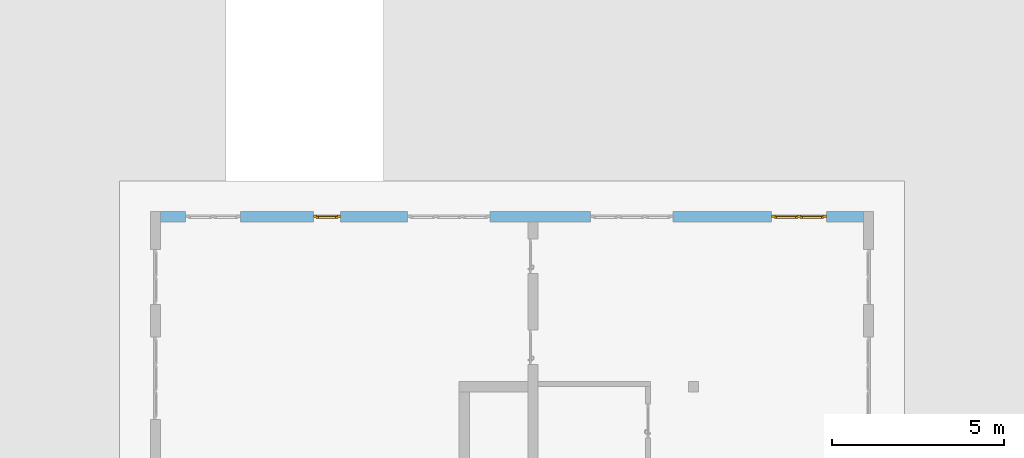
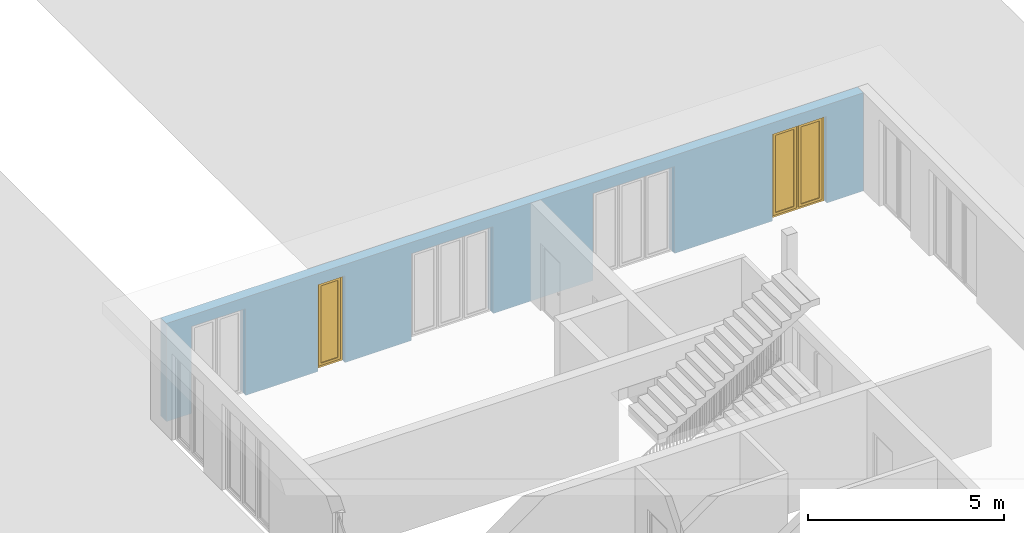
# One storey, part 16 of 23: 2 windows, 5 openings, plus 1 element that does not belong to this part.
"""IFC4 building model written with IfcOpenShell, lengths in metres."""

from ifc_helpers import new_model, entity, si_unit, converted_unit, derived_unit, direction, frame, origin_with_axes, place, context, subcontext, project, spatial, polygons, source, transform, mapped, material, type_object, element, fill, save


model = new_model("IFC4")

# Units and contexts
model_context = context("Model", 3, precision=1e-05, world=origin_with_axes(), true_north=direction((0.0, 1.0)))
body_context = subcontext(model_context, "Body", "Model", "MODEL_VIEW")
ifc_project = project(units=[si_unit("LENGTHUNIT", "METRE"), si_unit("AREAUNIT", "SQUARE_METRE"), si_unit("VOLUMEUNIT", "CUBIC_METRE"), converted_unit("PLANEANGLEUNIT", "DEGREE", entity("IfcPlaneAngleMeasure", 0.0174532925199), si_unit("PLANEANGLEUNIT", "RADIAN"), dimensions=[0, 0, 0, 0, 0, 0, 0]), converted_unit("TIMEUNIT", "Year", entity("IfcTimeMeasure", 31556926.0), si_unit("TIMEUNIT", "SECOND"), dimensions=[0, 0, 1, 0, 0, 0, 0]), si_unit("MASSUNIT", "GRAM", prefix="KILO"), si_unit("THERMODYNAMICTEMPERATUREUNIT", "DEGREE_CELSIUS"), si_unit("LUMINOUSINTENSITYUNIT", "LUMEN"), si_unit("ENERGYUNIT", "JOULE", prefix="MEGA"), derived_unit("THERMALCONDUCTANCEUNIT", [(si_unit("POWERUNIT", "WATT"), 1), (si_unit("LENGTHUNIT", "METRE"), -1), (si_unit("THERMODYNAMICTEMPERATUREUNIT", "KELVIN"), -1)]), derived_unit("SPECIFICHEATCAPACITYUNIT", [(si_unit("ENERGYUNIT", "JOULE"), 1), (si_unit("MASSUNIT", "GRAM", prefix="KILO"), -1), (si_unit("THERMODYNAMICTEMPERATUREUNIT", "KELVIN"), -1)]), derived_unit("MASSDENSITYUNIT", [(si_unit("MASSUNIT", "GRAM", prefix="KILO"), 1), (si_unit("VOLUMEUNIT", "CUBIC_METRE"), -1)])], contexts=[model_context])

# Site, building, storey
site_placement = place(None, origin_with_axes())
site = spatial("IfcSite", under=ifc_project, at=site_placement, CompositionType="ELEMENT")
building_placement = place(site_placement, origin_with_axes())
building = spatial("IfcBuilding", under=site, at=building_placement, CompositionType="ELEMENT")
storey_placement = place(building_placement, origin_with_axes())
storey = spatial("IfcBuildingStorey", under=building, at=storey_placement, Name="0. Geschoss", CompositionType="ELEMENT", Elevation=0.0)

# Wall, openings, windows
ifc_material = material()
wall_type = type_object("IfcWallType", Name="300", PredefinedType="NOTDEFINED")
wall_placement = place(storey_placement, frame((-11.7421993804, 8.92118776896, 0.0), z_axis=(0.0, 0.0, 1.0), x_axis=(1.0, 0.0, 0.0)))
wall = element("IfcWall", 1, at=wall_placement, inside=storey, type_object=wall_type, material=ifc_material, Name="Wand-001", PredefinedType="NOTDEFINED", context=body_context, shape_type="Tessellation", body=[
    polygons([(15.23, -0.1, 0.0), (15.23, -0.3, 0.0), (15.23, -0.3, 2.7), (15.23, 0.0, 2.7), (15.23, 0.0, 0.0), (18.102139809, 0.0, 0.0), (18.102139809, -0.3, 0.0), (18.102139809, -0.3, 2.7), (19.702139809, -0.3, 2.7), (19.702139809, -0.3, 0.0), (20.78, -0.3, 0.0), (20.78, -0.3, 3.05), (0.3, -0.3, 3.05), (0.3, -0.3, 0.0), (1.0288518641, -0.3, 0.0), (1.0288518641, -0.3, 2.7), (2.6288518641, -0.3, 2.7), (2.6288518641, -0.3, 0.0), (4.75, -0.3, 0.0), (4.75, -0.3, 2.7), (5.55, -0.3, 2.7), (5.55, -0.3, 0.0), (7.50089858046, -0.3, 0.0), (7.50089858046, -0.3, 2.7), (9.90089858046, -0.3, 2.7), (9.90089858046, -0.3, 0.0), (12.83, -0.3, 0.0), (12.83, -0.3, 2.7), (12.83, 0.0, 2.7), (12.83, 0.0, 0.0), (9.90089858046, 0.0, 0.0), (9.90089858046, 0.0, 2.7), (7.50089858046, 0.0, 2.7), (7.50089858046, 0.0, 0.0), (5.55, 0.0, 0.0), (5.55, 0.0, 2.7), (4.75, 0.0, 2.7), (4.75, 0.0, 0.0), (2.6288518641, 0.0, 0.0), (2.6288518641, 0.0, 2.7), (1.0288518641, 0.0, 2.7), (1.0288518641, 0.0, 0.0), (0.3, 0.0, 0.0), (0.3, 0.0, 3.05), (20.78, 0.0, 3.05), (20.78, 0.0, 0.0), (19.702139809, 0.0, 0.0), (19.702139809, 0.0, 2.7), (18.102139809, 0.0, 2.7), (12.83, -0.1, 0.0)], [[[1, 2, 3, 4, 5]], [[2, 1, 5, 6, 7]], [[3, 2, 7, 8, 9, 10, 11, 12, 13, 14, 15, 16, 17, 18, 19, 20, 21, 22, 23, 24, 25, 26, 27, 28]], [[4, 3, 28, 29]], [[6, 5, 4, 29, 30, 31, 32, 33, 34, 35, 36, 37, 38, 39, 40, 41, 42, 43, 44, 45, 46, 47, 48, 49]], [[6, 49, 8, 7]], [[8, 49, 48, 9]], [[48, 47, 10, 9]], [[46, 11, 10, 47]], [[12, 11, 46, 45]], [[45, 44, 13, 12]], [[44, 43, 14, 13]], [[15, 14, 43, 42]], [[16, 15, 42, 41]], [[40, 17, 16, 41]], [[18, 17, 40, 39]], [[19, 18, 39, 38]], [[20, 19, 38, 37]], [[36, 21, 20, 37]], [[22, 21, 36, 35]], [[22, 35, 34, 23]], [[34, 33, 24, 23]], [[24, 33, 32, 25]], [[32, 31, 26, 25]], [[50, 27, 26, 31, 30]], [[28, 27, 50, 30, 29]]], closed=True),
])
opening_1_placement = place(wall_placement, frame((1.8288518641, 0.0, 0.0), z_axis=(0.0, 0.0, 1.0), x_axis=(1.0, 0.0, 0.0)))
element("IfcOpeningElement", 2, at=opening_1_placement, cuts=wall, Name="Fenster-001", context=body_context, identifier="Reference", shape_type="Tessellation", body=[
    polygons([(-0.8, -0.1, 0.0), (-0.8, -0.1, 2.7), (-0.8, 0.000999999999998, 2.7), (-0.8, 0.000999999999998, 0.0), (-0.8, -0.301, 0.0), (-0.8, -0.301, 2.7), (0.8, -0.1, 2.7), (0.8, 0.000999999999999, 2.7), (0.8, -0.301, 2.7), (0.8, 0.000999999999999, 0.0), (0.8, -0.1, 0.0), (0.8, -0.301, 0.0)], [[[1, 2, 3, 4]], [[2, 1, 5, 6]], [[7, 8, 3, 2, 6, 9]], [[8, 10, 4, 3]], [[1, 4, 10, 11, 12, 5]], [[6, 5, 12, 9]], [[7, 11, 10, 8]], [[11, 7, 9, 12]]], closed=True),
])
opening_2_placement = place(wall_placement, frame((8.70089858046, 0.0, 0.0), z_axis=(0.0, 0.0, 1.0), x_axis=(1.0, 0.0, 0.0)))
element("IfcOpeningElement", 3, at=opening_2_placement, cuts=wall, Name="Fenster-002", context=body_context, identifier="Reference", shape_type="Tessellation", body=[
    polygons([(-1.2, -0.1, 0.0), (-1.2, -0.1, 2.7), (-1.2, 0.000999999999999, 2.7), (-1.2, 0.000999999999999, 0.0), (-1.2, -0.301, 0.0), (-1.2, -0.301, 2.7), (1.2, -0.1, 2.7), (1.2, 0.001, 2.7), (1.2, -0.301, 2.7), (1.2, 0.001, 0.0), (1.2, -0.1, 0.0), (1.2, -0.301, 0.0)], [[[1, 2, 3, 4]], [[2, 1, 5, 6]], [[7, 8, 3, 2, 6, 9]], [[8, 10, 4, 3]], [[1, 4, 10, 11, 12, 5]], [[6, 5, 12, 9]], [[7, 11, 10, 8]], [[11, 7, 9, 12]]], closed=True),
])
opening_3_placement = place(wall_placement, frame((5.15, 0.0, 0.0), z_axis=(0.0, 0.0, 1.0), x_axis=(1.0, 0.0, 0.0)))
opening_3 = element("IfcOpeningElement", 4, at=opening_3_placement, cuts=wall, Name="Fenster-003", context=body_context, identifier="Reference", shape_type="Tessellation", body=[
    polygons([(-0.4, -0.1, 0.0), (-0.4, -0.1, 2.7), (-0.4, 0.001, 2.7), (-0.4, 0.001, 0.0), (-0.4, -0.301, 0.0), (-0.4, -0.301, 2.7), (0.4, -0.1, 2.7), (0.4, 0.001, 2.7), (0.4, -0.301, 2.7), (0.4, 0.001, 0.0), (0.4, -0.1, 0.0), (0.4, -0.301, 0.0)], [[[1, 2, 3, 4]], [[2, 1, 5, 6]], [[7, 8, 3, 2, 6, 9]], [[8, 10, 4, 3]], [[1, 4, 10, 11, 12, 5]], [[6, 5, 12, 9]], [[7, 11, 10, 8]], [[11, 7, 9, 12]]], closed=True),
])
opening_4_placement = place(wall_placement, frame((18.902139809, 0.0, 0.0), z_axis=(0.0, 0.0, 1.0), x_axis=(1.0, 0.0, 0.0)))
opening_4 = element("IfcOpeningElement", 5, at=opening_4_placement, cuts=wall, Name="Fenster-001", context=body_context, identifier="Reference", shape_type="Tessellation", body=[
    polygons([(-0.8, -0.1, 0.0), (-0.8, -0.1, 2.7), (-0.8, 0.001, 2.7), (-0.8, 0.001, 0.0), (-0.8, -0.301, 0.0), (-0.8, -0.301, 2.7), (0.8, -0.1, 2.7), (0.8, 0.001, 2.7), (0.8, -0.301, 2.7), (0.8, 0.001, 0.0), (0.8, -0.1, 0.0), (0.8, -0.301, 0.0)], [[[1, 2, 3, 4]], [[2, 1, 5, 6]], [[7, 8, 3, 2, 6, 9]], [[8, 10, 4, 3]], [[1, 4, 10, 11, 12, 5]], [[6, 5, 12, 9]], [[7, 11, 10, 8]], [[11, 7, 9, 12]]], closed=True),
])
opening_5_placement = place(wall_placement, frame((14.03, 0.0, 0.0), z_axis=(0.0, 0.0, 1.0), x_axis=(1.0, 0.0, 0.0)))
element("IfcOpeningElement", 6, at=opening_5_placement, cuts=wall, Name="Fenster-002", context=body_context, identifier="Reference", shape_type="Tessellation", body=[
    polygons([(-1.2, -0.1, 0.0), (-1.2, -0.1, 2.7), (-1.2, 0.001, 2.7), (-1.2, 0.001, 0.0), (-1.2, -0.301, 0.0), (-1.2, -0.301, 2.7), (1.2, -0.1, 2.7), (1.2, 0.001, 2.7), (1.2, -0.301, 2.7), (1.2, 0.001, 0.0), (1.2, -0.1, 0.0), (1.2, -0.301, 0.0)], [[[1, 2, 3, 4]], [[2, 1, 5, 6]], [[7, 8, 3, 2, 6, 9]], [[8, 10, 4, 3]], [[1, 4, 10, 11, 12, 5]], [[6, 5, 12, 9]], [[7, 11, 10, 8]], [[11, 7, 9, 12]]], closed=True),
])
window_type_1 = type_object("IfcWindowType", Name="2-1+1 26", PartitioningType="DOUBLE_PANEL_VERTICAL", PredefinedType="WINDOW")
shared_shape_1 = source(origin_with_axes(), body_context, "Body", "Tessellation", [
    polygons([(-0.8, -0.07, 0.0), (-0.8, 0.0, 0.0), (-0.7, 0.0, 0.1), (-0.7, -0.07, 0.1), (-0.8, -0.07, 2.7), (-0.8, 0.0, 2.7), (-0.7, 0.0, 2.6), (-0.7, -0.07, 2.6)], [[[1, 2, 3, 4]], [[5, 6, 2, 1]], [[2, 6, 7, 3]], [[4, 3, 7, 8]], [[1, 4, 8, 5]], [[8, 7, 6, 5]]], closed=True),
    polygons([(0.8, -0.07, 0.0), (0.8, 0.0, 0.0), (0.8, 0.0, 2.7), (0.8, -0.07, 2.7), (0.7, -0.07, 0.1), (0.7, 0.0, 0.1), (0.7, 0.0, 2.6), (0.7, -0.07, 2.6)], [[[1, 2, 3, 4]], [[5, 6, 2, 1]], [[2, 6, 7, 3]], [[4, 3, 7, 8]], [[1, 4, 8, 5]], [[8, 7, 6, 5]]], closed=True),
    polygons([(-0.8, -0.07, 0.0), (-0.8, 0.0, 0.0), (0.8, 0.0, 0.0), (0.8, -0.07, 0.0), (-0.7, -0.07, 0.1), (-0.7, 0.0, 0.1), (-0.05, 0.0, 0.1), (0.05, 0.0, 0.1), (0.7, 0.0, 0.1), (0.7, -0.07, 0.1), (0.05, -0.07, 0.1), (-0.05, -0.07, 0.1)], [[[1, 2, 3, 4]], [[5, 6, 2, 1]], [[2, 6, 7, 8, 9, 3]], [[4, 3, 9, 10]], [[1, 4, 10, 11, 12, 5]], [[12, 7, 6, 5]], [[11, 8, 7, 12]], [[10, 9, 8, 11]]], closed=True),
    polygons([(-0.8, -0.07, 2.7), (-0.8, 0.0, 2.7), (-0.7, 0.0, 2.6), (-0.7, -0.07, 2.6), (0.8, -0.07, 2.7), (0.8, 0.0, 2.7), (0.7, 0.0, 2.6), (0.05, 0.0, 2.6), (-0.05, 0.0, 2.6), (-0.05, -0.07, 2.6), (0.05, -0.07, 2.6), (0.7, -0.07, 2.6)], [[[1, 2, 3, 4]], [[5, 6, 2, 1]], [[2, 6, 7, 8, 9, 3]], [[4, 3, 9, 10]], [[1, 4, 10, 11, 12, 5]], [[12, 7, 6, 5]], [[11, 8, 7, 12]], [[10, 9, 8, 11]]], closed=True),
    polygons([(-0.05, -0.07, 0.1), (-0.05, 0.0, 0.1), (0.05, 0.0, 0.1), (0.05, -0.07, 0.1), (-0.05, -0.07, 2.6), (-0.05, 0.0, 2.6), (0.05, 0.0, 2.6), (0.05, -0.07, 2.6)], [[[1, 2, 3, 4]], [[5, 6, 2, 1]], [[2, 6, 7, 3]], [[4, 3, 7, 8]], [[1, 4, 8, 5]], [[8, 7, 6, 5]]], closed=True),
    polygons([(-0.72, 0.0, 0.08), (-0.72, 0.03, 0.08), (-0.65, 0.03, 0.15), (-0.65, 0.0, 0.15), (-0.72, 0.0, 2.62), (-0.72, 0.03, 2.62), (-0.65, 0.03, 2.55), (-0.65, 0.0, 2.55)], [[[1, 2, 3, 4]], [[5, 6, 2, 1]], [[2, 6, 7, 3]], [[4, 3, 7, 8]], [[1, 4, 8, 5]], [[8, 7, 6, 5]]], closed=True),
    polygons([(-0.03, 0.0, 0.08), (-0.1, 0.0, 0.15), (-0.1, 0.03, 0.15), (-0.03, 0.03, 0.08), (-0.03, 0.0, 2.62), (-0.1, 0.0, 2.55), (-0.1, 0.03, 2.55), (-0.03, 0.03, 2.62)], [[[1, 2, 3, 4]], [[1, 5, 6, 2]], [[2, 6, 7, 3]], [[4, 3, 7, 8]], [[5, 1, 4, 8]], [[6, 5, 8, 7]]], closed=True),
    polygons([(-0.72, 0.0, 0.08), (-0.72, 0.03, 0.08), (-0.03, 0.03, 0.08), (-0.03, 0.0, 0.08), (-0.65, 0.0, 0.15), (-0.65, 0.03, 0.15), (-0.1, 0.03, 0.15), (-0.1, 0.0, 0.15)], [[[1, 2, 3, 4]], [[5, 6, 2, 1]], [[2, 6, 7, 3]], [[4, 3, 7, 8]], [[1, 4, 8, 5]], [[8, 7, 6, 5]]], closed=True),
    polygons([(-0.72, 0.0, 2.62), (-0.03, 0.0, 2.62), (-0.03, 0.03, 2.62), (-0.72, 0.03, 2.62), (-0.65, 0.0, 2.55), (-0.1, 0.0, 2.55), (-0.1, 0.03, 2.55), (-0.65, 0.03, 2.55)], [[[1, 2, 3, 4]], [[1, 5, 6, 2]], [[2, 6, 7, 3]], [[4, 3, 7, 8]], [[5, 1, 4, 8]], [[6, 5, 8, 7]]], closed=True),
    polygons([(-0.7, -0.03, 0.1), (-0.7, 0.0, 0.1), (-0.65, 0.0, 0.15), (-0.65, -0.03, 0.15), (-0.7, -0.03, 2.6), (-0.7, 0.0, 2.6), (-0.65, 0.0, 2.55), (-0.65, -0.03, 2.55)], [[[1, 2, 3, 4]], [[5, 6, 2, 1]], [[2, 6, 7, 3]], [[4, 3, 7, 8]], [[1, 4, 8, 5]], [[8, 7, 6, 5]]], closed=True),
    polygons([(-0.05, -0.03, 0.1), (-0.1, -0.03, 0.15), (-0.1, 0.0, 0.15), (-0.05, 0.0, 0.1), (-0.05, -0.03, 2.6), (-0.1, -0.03, 2.55), (-0.1, 0.0, 2.55), (-0.05, 0.0, 2.6)], [[[1, 2, 3, 4]], [[1, 5, 6, 2]], [[2, 6, 7, 3]], [[4, 3, 7, 8]], [[5, 1, 4, 8]], [[6, 5, 8, 7]]], closed=True),
    polygons([(-0.7, -0.03, 0.1), (-0.7, 0.0, 0.1), (-0.05, 0.0, 0.1), (-0.05, -0.03, 0.1), (-0.65, -0.03, 0.15), (-0.65, 0.0, 0.15), (-0.1, 0.0, 0.15), (-0.1, -0.03, 0.15)], [[[1, 2, 3, 4]], [[5, 6, 2, 1]], [[2, 6, 7, 3]], [[4, 3, 7, 8]], [[1, 4, 8, 5]], [[8, 7, 6, 5]]], closed=True),
    polygons([(-0.7, -0.03, 2.6), (-0.05, -0.03, 2.6), (-0.05, 0.0, 2.6), (-0.7, 0.0, 2.6), (-0.65, -0.03, 2.55), (-0.1, -0.03, 2.55), (-0.1, 0.0, 2.55), (-0.65, 0.0, 2.55)], [[[1, 2, 3, 4]], [[1, 5, 6, 2]], [[2, 6, 7, 3]], [[4, 3, 7, 8]], [[5, 1, 4, 8]], [[6, 5, 8, 7]]], closed=True),
    polygons([(-0.65, -0.005, 0.15), (-0.65, 0.005, 0.15), (-0.1, 0.005, 0.15), (-0.1, -0.005, 0.15), (-0.65, -0.005, 2.55), (-0.65, 0.005, 2.55), (-0.1, 0.005, 2.55), (-0.1, -0.005, 2.55)], [[[1, 2, 3, 4]], [[5, 6, 2, 1]], [[2, 6, 7, 3]], [[4, 3, 7, 8]], [[1, 4, 8, 5]], [[8, 7, 6, 5]]], closed=True),
    polygons([(0.03, 0.0, 0.08), (0.03, 0.03, 0.08), (0.1, 0.03, 0.15), (0.1, 0.0, 0.15), (0.03, 0.0, 2.62), (0.03, 0.03, 2.62), (0.1, 0.03, 2.55), (0.1, 0.0, 2.55)], [[[1, 2, 3, 4]], [[5, 6, 2, 1]], [[2, 6, 7, 3]], [[4, 3, 7, 8]], [[1, 4, 8, 5]], [[8, 7, 6, 5]]], closed=True),
    polygons([(0.72, 0.0, 0.08), (0.65, 0.0, 0.15), (0.65, 0.03, 0.15), (0.72, 0.03, 0.08), (0.72, 0.0, 2.62), (0.65, 0.0, 2.55), (0.65, 0.03, 2.55), (0.72, 0.03, 2.62)], [[[1, 2, 3, 4]], [[1, 5, 6, 2]], [[2, 6, 7, 3]], [[4, 3, 7, 8]], [[5, 1, 4, 8]], [[6, 5, 8, 7]]], closed=True),
    polygons([(0.03, 0.0, 0.08), (0.03, 0.03, 0.08), (0.72, 0.03, 0.08), (0.72, 0.0, 0.08), (0.1, 0.0, 0.15), (0.1, 0.03, 0.15), (0.65, 0.03, 0.15), (0.65, 0.0, 0.15)], [[[1, 2, 3, 4]], [[5, 6, 2, 1]], [[2, 6, 7, 3]], [[4, 3, 7, 8]], [[1, 4, 8, 5]], [[8, 7, 6, 5]]], closed=True),
    polygons([(0.03, 0.0, 2.62), (0.72, 0.0, 2.62), (0.72, 0.03, 2.62), (0.03, 0.03, 2.62), (0.1, 0.0, 2.55), (0.65, 0.0, 2.55), (0.65, 0.03, 2.55), (0.1, 0.03, 2.55)], [[[1, 2, 3, 4]], [[1, 5, 6, 2]], [[2, 6, 7, 3]], [[4, 3, 7, 8]], [[5, 1, 4, 8]], [[6, 5, 8, 7]]], closed=True),
    polygons([(0.05, -0.03, 0.1), (0.05, 0.0, 0.1), (0.1, 0.0, 0.15), (0.1, -0.03, 0.15), (0.05, -0.03, 2.6), (0.05, 0.0, 2.6), (0.1, 0.0, 2.55), (0.1, -0.03, 2.55)], [[[1, 2, 3, 4]], [[5, 6, 2, 1]], [[2, 6, 7, 3]], [[4, 3, 7, 8]], [[1, 4, 8, 5]], [[8, 7, 6, 5]]], closed=True),
    polygons([(0.7, -0.03, 0.1), (0.65, -0.03, 0.15), (0.65, 0.0, 0.15), (0.7, 0.0, 0.1), (0.7, -0.03, 2.6), (0.65, -0.03, 2.55), (0.65, 0.0, 2.55), (0.7, 0.0, 2.6)], [[[1, 2, 3, 4]], [[1, 5, 6, 2]], [[2, 6, 7, 3]], [[4, 3, 7, 8]], [[5, 1, 4, 8]], [[6, 5, 8, 7]]], closed=True),
    polygons([(0.05, -0.03, 0.1), (0.05, 0.0, 0.1), (0.7, 0.0, 0.1), (0.7, -0.03, 0.1), (0.1, -0.03, 0.15), (0.1, 0.0, 0.15), (0.65, 0.0, 0.15), (0.65, -0.03, 0.15)], [[[1, 2, 3, 4]], [[5, 6, 2, 1]], [[2, 6, 7, 3]], [[4, 3, 7, 8]], [[1, 4, 8, 5]], [[8, 7, 6, 5]]], closed=True),
    polygons([(0.05, -0.03, 2.6), (0.7, -0.03, 2.6), (0.7, 0.0, 2.6), (0.05, 0.0, 2.6), (0.1, -0.03, 2.55), (0.65, -0.03, 2.55), (0.65, 0.0, 2.55), (0.1, 0.0, 2.55)], [[[1, 2, 3, 4]], [[1, 5, 6, 2]], [[2, 6, 7, 3]], [[4, 3, 7, 8]], [[5, 1, 4, 8]], [[6, 5, 8, 7]]], closed=True),
    polygons([(0.1, -0.005, 0.15), (0.1, 0.005, 0.15), (0.65, 0.005, 0.15), (0.65, -0.005, 0.15), (0.1, -0.005, 2.55), (0.1, 0.005, 2.55), (0.65, 0.005, 2.55), (0.65, -0.005, 2.55)], [[[1, 2, 3, 4]], [[5, 6, 2, 1]], [[2, 6, 7, 3]], [[4, 3, 7, 8]], [[1, 4, 8, 5]], [[8, 7, 6, 5]]], closed=True),
])
window_1_placement = place(opening_4_placement, frame((0.8, 0.0, 0.0), z_axis=(0.0, 0.0, 1.0), x_axis=(-1.0, 0.0, 0.0)))
window_1 = element("IfcWindow", 7, at=window_1_placement, inside=storey, type_object=window_type_1, Name="Fenster-001", OverallHeight=2.7, OverallWidth=1.6, PredefinedType="WINDOW", context=body_context, shape_type="MappedRepresentation", body=[
    mapped(shared_shape_1, transform((0.8, 0.17, 0.0))),
])
fill(opening_4, window_1)
window_type_2 = type_object("IfcWindowType", Name="1-26", PartitioningType="SINGLE_PANEL", PredefinedType="WINDOW")
shared_shape_2 = source(origin_with_axes(), body_context, "Body", "Tessellation", [
    polygons([(0.4, -0.07, 0.0), (0.3, -0.07, 0.1), (0.3, 0.0, 0.1), (0.4, 0.0, 0.0), (0.4, -0.07, 2.7), (0.3, -0.07, 2.6), (0.3, 0.0, 2.6), (0.4, 0.0, 2.7)], [[[1, 2, 3, 4]], [[1, 5, 6, 2]], [[2, 6, 7, 3]], [[4, 3, 7, 8]], [[5, 1, 4, 8]], [[6, 5, 8, 7]]], closed=True),
    polygons([(-0.4, -0.07, 0.0), (-0.4, -0.07, 2.7), (-0.4, 0.0, 2.7), (-0.4, 0.0, 0.0), (-0.3, -0.07, 0.1), (-0.3, -0.07, 2.6), (-0.3, 0.0, 2.6), (-0.3, 0.0, 0.1)], [[[1, 2, 3, 4]], [[1, 5, 6, 2]], [[2, 6, 7, 3]], [[4, 3, 7, 8]], [[5, 1, 4, 8]], [[6, 5, 8, 7]]], closed=True),
    polygons([(0.4, -0.07, 0.0), (-0.4, -0.07, 0.0), (-0.4, 0.0, 0.0), (0.4, 0.0, 0.0), (0.3, -0.07, 0.1), (0.0, -0.07, 0.1), (-0.3, -0.07, 0.1), (-0.3, 0.0, 0.1), (0.0, 0.0, 0.1), (0.3, 0.0, 0.1)], [[[1, 2, 3, 4]], [[1, 5, 6, 7, 2]], [[2, 7, 8, 3]], [[4, 3, 8, 9, 10]], [[5, 1, 4, 10]], [[6, 5, 10, 9]], [[7, 6, 9, 8]]], closed=True),
    polygons([(0.4, -0.07, 2.7), (0.3, -0.07, 2.6), (0.3, 0.0, 2.6), (0.4, 0.0, 2.7), (-0.4, -0.07, 2.7), (-0.3, -0.07, 2.6), (0.0, -0.07, 2.6), (0.0, 0.0, 2.6), (-0.3, 0.0, 2.6), (-0.4, 0.0, 2.7)], [[[1, 2, 3, 4]], [[1, 5, 6, 7, 2]], [[2, 7, 8, 3]], [[4, 3, 8, 9, 10]], [[5, 1, 4, 10]], [[6, 5, 10, 9]], [[7, 6, 9, 8]]], closed=True),
    polygons([(0.32, 0.0, 0.08), (0.25, 0.0, 0.15), (0.25, 0.03, 0.15), (0.32, 0.03, 0.08), (0.32, 0.0, 2.62), (0.25, 0.0, 2.55), (0.25, 0.03, 2.55), (0.32, 0.03, 2.62)], [[[1, 2, 3, 4]], [[1, 5, 6, 2]], [[2, 6, 7, 3]], [[4, 3, 7, 8]], [[5, 1, 4, 8]], [[6, 5, 8, 7]]], closed=True),
    polygons([(-0.32, 0.0, 0.08), (-0.32, 0.03, 0.08), (-0.25, 0.03, 0.15), (-0.25, 0.0, 0.15), (-0.32, 0.0, 2.62), (-0.32, 0.03, 2.62), (-0.25, 0.03, 2.55), (-0.25, 0.0, 2.55)], [[[1, 2, 3, 4]], [[5, 6, 2, 1]], [[2, 6, 7, 3]], [[4, 3, 7, 8]], [[1, 4, 8, 5]], [[8, 7, 6, 5]]], closed=True),
    polygons([(0.32, 0.0, 0.08), (-0.32, 0.0, 0.08), (-0.32, 0.03, 0.08), (0.32, 0.03, 0.08), (0.25, 0.0, 0.15), (-0.25, 0.0, 0.15), (-0.25, 0.03, 0.15), (0.25, 0.03, 0.15)], [[[1, 2, 3, 4]], [[1, 5, 6, 2]], [[2, 6, 7, 3]], [[4, 3, 7, 8]], [[5, 1, 4, 8]], [[6, 5, 8, 7]]], closed=True),
    polygons([(0.32, 0.0, 2.62), (0.32, 0.03, 2.62), (-0.32, 0.03, 2.62), (-0.32, 0.0, 2.62), (0.25, 0.0, 2.55), (0.25, 0.03, 2.55), (-0.25, 0.03, 2.55), (-0.25, 0.0, 2.55)], [[[1, 2, 3, 4]], [[5, 6, 2, 1]], [[2, 6, 7, 3]], [[4, 3, 7, 8]], [[1, 4, 8, 5]], [[8, 7, 6, 5]]], closed=True),
    polygons([(0.3, -0.03, 0.1), (0.25, -0.03, 0.15), (0.25, 0.0, 0.15), (0.3, 0.0, 0.1), (0.3, -0.03, 2.6), (0.25, -0.03, 2.55), (0.25, 0.0, 2.55), (0.3, 0.0, 2.6)], [[[1, 2, 3, 4]], [[1, 5, 6, 2]], [[2, 6, 7, 3]], [[4, 3, 7, 8]], [[5, 1, 4, 8]], [[6, 5, 8, 7]]], closed=True),
    polygons([(-0.3, -0.03, 0.1), (-0.3, 0.0, 0.1), (-0.25, 0.0, 0.15), (-0.25, -0.03, 0.15), (-0.3, -0.03, 2.6), (-0.3, 0.0, 2.6), (-0.25, 0.0, 2.55), (-0.25, -0.03, 2.55)], [[[1, 2, 3, 4]], [[5, 6, 2, 1]], [[2, 6, 7, 3]], [[4, 3, 7, 8]], [[1, 4, 8, 5]], [[8, 7, 6, 5]]], closed=True),
    polygons([(0.3, -0.03, 0.1), (-0.3, -0.03, 0.1), (-0.3, 0.0, 0.1), (0.3, 0.0, 0.1), (0.25, -0.03, 0.15), (-0.25, -0.03, 0.15), (-0.25, 0.0, 0.15), (0.25, 0.0, 0.15)], [[[1, 2, 3, 4]], [[1, 5, 6, 2]], [[2, 6, 7, 3]], [[4, 3, 7, 8]], [[5, 1, 4, 8]], [[6, 5, 8, 7]]], closed=True),
    polygons([(0.3, -0.03, 2.6), (0.3, 0.0, 2.6), (-0.3, 0.0, 2.6), (-0.3, -0.03, 2.6), (0.25, -0.03, 2.55), (0.25, 0.0, 2.55), (-0.25, 0.0, 2.55), (-0.25, -0.03, 2.55)], [[[1, 2, 3, 4]], [[5, 6, 2, 1]], [[2, 6, 7, 3]], [[4, 3, 7, 8]], [[1, 4, 8, 5]], [[8, 7, 6, 5]]], closed=True),
    polygons([(0.25, -0.005, 0.15), (-0.25, -0.005, 0.15), (-0.25, 0.005, 0.15), (0.25, 0.005, 0.15), (0.25, -0.005, 2.55), (-0.25, -0.005, 2.55), (-0.25, 0.005, 2.55), (0.25, 0.005, 2.55)], [[[1, 2, 3, 4]], [[1, 5, 6, 2]], [[2, 6, 7, 3]], [[4, 3, 7, 8]], [[5, 1, 4, 8]], [[6, 5, 8, 7]]], closed=True),
])
window_2_placement = place(opening_3_placement, frame((0.4, 0.0, 0.0), z_axis=(0.0, 0.0, 1.0), x_axis=(-1.0, 0.0, 0.0)))
window_2 = element("IfcWindow", 8, at=window_2_placement, inside=storey, type_object=window_type_2, Name="Fenster-003", OverallHeight=2.7, OverallWidth=0.8, PredefinedType="WINDOW", context=body_context, shape_type="MappedRepresentation", body=[
    mapped(shared_shape_2, transform((0.4, 0.17, 0.0))),
])
fill(opening_3, window_2)

save(model, "model.ifc")
